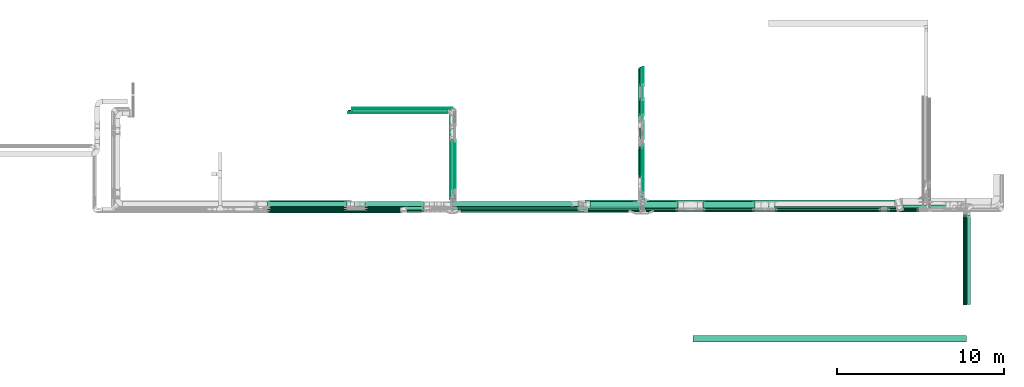
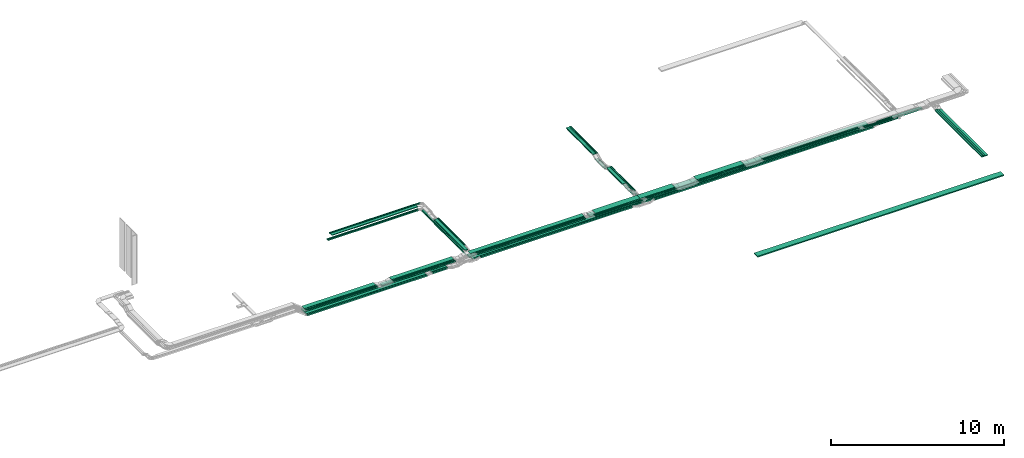
# One storey, part 2 of 28: 66 flow segments.
"""IFC2X3 building model written with IfcOpenShell, lengths in millimetres."""

from ifc_helpers import new_model, entity, si_unit, converted_unit, derived_unit, direction, frame, frame_2d, origin, origin_2d_with_axis, place, context, subcontext, project, spatial, rectangle, extrude, type_object, element, save


model = new_model("IFC2X3")

# Units and contexts
model_context = context("Model", 3, precision=0.01, world=origin(), true_north=direction((6.12303176911189e-17, 1.0)))
body_context = subcontext(model_context, "Body", "Model", "MODEL_VIEW")
ifc_project = project(units=[si_unit("LENGTHUNIT", "METRE", prefix="MILLI"), si_unit("AREAUNIT", "SQUARE_METRE"), si_unit("VOLUMEUNIT", "CUBIC_METRE"), converted_unit("PLANEANGLEUNIT", "DEGREE", entity("IfcRatioMeasure", 0.0174532925199433), si_unit("PLANEANGLEUNIT", "RADIAN"), dimensions=[0, 0, 0, 0, 0, 0, 0]), si_unit("MASSUNIT", "GRAM", prefix="KILO"), derived_unit("MASSDENSITYUNIT", [(si_unit("MASSUNIT", "GRAM", prefix="KILO"), 1), (si_unit("LENGTHUNIT", "METRE"), -3)]), derived_unit("MOMENTOFINERTIAUNIT", [(si_unit("LENGTHUNIT", "METRE"), 4)]), si_unit("TIMEUNIT", "SECOND"), si_unit("FREQUENCYUNIT", "HERTZ"), si_unit("THERMODYNAMICTEMPERATUREUNIT", "DEGREE_CELSIUS"), derived_unit("THERMALTRANSMITTANCEUNIT", [(si_unit("MASSUNIT", "GRAM", prefix="KILO"), 1), (si_unit("THERMODYNAMICTEMPERATUREUNIT", "KELVIN"), -1), (si_unit("TIMEUNIT", "SECOND"), -3)]), derived_unit("VOLUMETRICFLOWRATEUNIT", [(si_unit("LENGTHUNIT", "METRE"), 3), (si_unit("TIMEUNIT", "SECOND"), -1)]), derived_unit("MASSFLOWRATEUNIT", [(si_unit("MASSUNIT", "GRAM", prefix="KILO"), 1), (si_unit("TIMEUNIT", "SECOND"), -1)]), derived_unit("ROTATIONALFREQUENCYUNIT", [(si_unit("TIMEUNIT", "SECOND"), -1)]), si_unit("ELECTRICCURRENTUNIT", "AMPERE"), si_unit("ELECTRICVOLTAGEUNIT", "VOLT"), si_unit("POWERUNIT", "WATT"), si_unit("FORCEUNIT", "NEWTON", prefix="KILO"), si_unit("ILLUMINANCEUNIT", "LUX"), si_unit("LUMINOUSFLUXUNIT", "LUMEN"), si_unit("LUMINOUSINTENSITYUNIT", "CANDELA"), derived_unit("USERDEFINED", [(si_unit("MASSUNIT", "GRAM", prefix="KILO"), -1), (si_unit("LENGTHUNIT", "METRE"), -2), (si_unit("TIMEUNIT", "SECOND"), 3), (si_unit("LUMINOUSFLUXUNIT", "LUMEN"), 1)]), derived_unit("LINEARVELOCITYUNIT", [(si_unit("LENGTHUNIT", "METRE"), 1), (si_unit("TIMEUNIT", "SECOND"), -1)]), si_unit("PRESSUREUNIT", "PASCAL"), derived_unit("USERDEFINED", [(si_unit("LENGTHUNIT", "METRE"), -2), (si_unit("MASSUNIT", "GRAM", prefix="KILO"), 1), (si_unit("TIMEUNIT", "SECOND"), -2)]), derived_unit("LINEARFORCEUNIT", [(si_unit("MASSUNIT", "GRAM", prefix="KILO"), 1), (si_unit("LENGTHUNIT", "METRE"), 1), (si_unit("TIMEUNIT", "SECOND"), -2), (si_unit("LENGTHUNIT", "METRE"), -1)]), derived_unit("PLANARFORCEUNIT", [(si_unit("MASSUNIT", "GRAM", prefix="KILO"), 1), (si_unit("LENGTHUNIT", "METRE"), 1), (si_unit("TIMEUNIT", "SECOND"), -2), (si_unit("LENGTHUNIT", "METRE"), -2)])], contexts=[model_context])

# Site, building, storey
site_placement = place(None, frame((0.0, -0.00077364408347762, 0.0)))
site = spatial("IfcSite", under=ifc_project, at=site_placement, CompositionType="ELEMENT")
building_placement = place(site_placement, origin())
building = spatial("IfcBuilding", under=site, at=building_placement, CompositionType="ELEMENT")
storey_placement = place(building_placement, origin())
storey = spatial("IfcBuildingStorey", under=building, at=storey_placement, CompositionType="ELEMENT", Elevation=0.0)

# Flow segments
cable_carrier_segment_type = type_object("IfcCableCarrierSegmentType", PredefinedType="CABLETRAYSEGMENT")
flow_segment_1_placement = place(storey_placement, frame((54929.7964531974, 8300.00006103523, 2850.0)))
element("IfcFlowSegment", 1, at=flow_segment_1_placement, inside=storey, type_object=cable_carrier_segment_type, context=body_context, shape_type="SweptSolid", body=[
    extrude(rectangle(XDim=6370.08732356079, YDim=99.9999999999989, at=frame_2d((4.54747350886464e-12, 5.40012479177676e-13), x_axis=(1.0, 0.0))), frame((3185.04366178039, 50.0, 0.0), z_axis=(0.0, 0.0, 1.0), x_axis=(-1.0, 0.0, 0.0)), (0.0, 0.0, 1.0), 49.9999999999995),
])
flow_segment_2_placement = place(storey_placement, frame((47132.1688929495, 8410.00006103511, 2850.0)))
element("IfcFlowSegment", 2, at=flow_segment_2_placement, inside=storey, type_object=cable_carrier_segment_type, context=body_context, shape_type="SweptSolid", body=[
    extrude(rectangle(XDim=2006.37627300281, YDim=100.000000000001, at=frame_2d((0.0, -5.43565192856477e-13), x_axis=(1.0, 0.0))), frame((1003.18813650141, 50.0, 0.0)), (0.0, 0.0, 1.0), 49.9999999999995),
])
flow_segment_3_placement = place(storey_placement, frame((46843.1849606245, 8520.00006103514, 2850.0)))
element("IfcFlowSegment", 3, at=flow_segment_3_placement, inside=storey, type_object=cable_carrier_segment_type, context=body_context, shape_type="SweptSolid", body=[
    extrude(rectangle(XDim=2295.36020532801, YDim=400.0, at=frame_2d((4.32009983342141e-12, 0.0), x_axis=(1.0, 0.0))), frame((1147.68010266401, 200.0, 0.0)), (0.0, 0.0, 1.0), 49.9999999999995),
])
flow_segment_4_placement = place(storey_placement, frame((35521.1085349589, 8620.00006103516, 2600.0)))
element("IfcFlowSegment", 4, at=flow_segment_4_placement, inside=storey, type_object=cable_carrier_segment_type, context=body_context, shape_type="SweptSolid", body=[
    extrude(rectangle(XDim=7219.09376803744, YDim=299.999999999999, at=frame_2d((-2.04636307898909e-12, 5.40012479177676e-13), x_axis=(1.0, 0.0))), frame((3609.54688401872, 150.0, 0.0)), (0.0, 0.0, 1.0), 100.0),
])
flow_segment_5_placement = place(storey_placement, frame((24527.3148481445, 8570.00006103521, 2600.0)))
element("IfcFlowSegment", 5, at=flow_segment_5_placement, inside=storey, type_object=cable_carrier_segment_type, context=body_context, shape_type="SweptSolid", body=[
    extrude(rectangle(XDim=4983.74700171906, YDim=400.0, at=frame_2d((0.0, -5.54223333892878e-13), x_axis=(1.0, 0.0))), frame((2491.87350085953, 200.0, 0.0), z_axis=(0.0, 0.0, 1.0), x_axis=(-1.0, 0.0, 0.0)), (0.0, 0.0, 1.0), 100.0),
])
flow_segment_6_placement = place(storey_placement, frame((62655.5743759365, 8400.00006103516, 2600.0)))
element("IfcFlowSegment", 6, at=flow_segment_6_placement, inside=storey, type_object=cable_carrier_segment_type, context=body_context, shape_type="SweptSolid", body=[
    extrude(rectangle(XDim=1271.610584688, YDim=99.9999999999989, at=frame_2d((-4.32009983342141e-12, 1.08357767203415e-12), x_axis=(1.0, 0.0))), frame((635.805292344005, 50.0, 0.0)), (0.0, 0.0, 1.0), 100.0),
])
flow_segment_7_placement = place(storey_placement, frame((46898.1697248974, 8410.17178445353, 2600.0)))
element("IfcFlowSegment", 7, at=flow_segment_7_placement, inside=storey, type_object=cable_carrier_segment_type, context=body_context, shape_type="SweptSolid", body=[
    extrude(rectangle(XDim=15296.8333798477, YDim=200.0, at=origin_2d_with_axis()), frame((7648.41668992383, 100.0, 0.0), z_axis=(0.0, 0.0, 1.0), x_axis=(-1.0, 0.0, 0.0)), (0.0, 0.0, 1.0), 100.0),
])
flow_segment_8_placement = place(storey_placement, frame((47045.820904201, 8620.17178445353, 2600.0)))
element("IfcFlowSegment", 8, at=flow_segment_8_placement, inside=storey, type_object=cable_carrier_segment_type, context=body_context, shape_type="SweptSolid", body=[
    extrude(rectangle(XDim=15060.2769853209, YDim=400.0, at=frame_2d((-4.54747350886464e-12, 5.54223333892878e-13), x_axis=(1.0, 0.0))), frame((7530.13849266045, 200.0, 0.0), z_axis=(0.0, 0.0, 1.0), x_axis=(-1.0, 0.0, 0.0)), (0.0, 0.0, 1.0), 100.0),
])
flow_segment_9_placement = place(storey_placement, frame((62638.6221876818, 8514.3275570197, 2600.0)))
element("IfcFlowSegment", 9, at=flow_segment_9_placement, inside=storey, type_object=cable_carrier_segment_type, context=body_context, shape_type="SweptSolid", body=[
    extrude(rectangle(XDim=1418.74753721558, YDim=200.0, at=frame_2d((4.32009983342141e-12, 0.0), x_axis=(1.0, 0.0))), frame((709.373768607787, 100.0, 0.0)), (0.0, 0.0, 1.0), 100.0),
])
flow_segment_10_placement = place(storey_placement, frame((64058.1697248974, 8514.3275570197, 2600.0)))
element("IfcFlowSegment", 10, at=flow_segment_10_placement, inside=storey, type_object=cable_carrier_segment_type, context=body_context, shape_type="SweptSolid", body=[
    extrude(rectangle(XDim=1550.00000000001, YDim=200.0, at=frame_2d((0.0, 5.47117906535277e-13), x_axis=(1.0, 0.0))), frame((775.0, 100.0, 0.0)), (0.0, 0.0, 1.0), 100.000000000001),
])
flow_segment_11_placement = place(storey_placement, frame((46847.7697248975, 15822.7995563986, 2600.0)))
element("IfcFlowSegment", 11, at=flow_segment_11_placement, inside=storey, type_object=cable_carrier_segment_type, context=body_context, shape_type="SweptSolid", body=[
    extrude(rectangle(XDim=1137.0957799209, YDim=99.9999999999946, at=origin_2d_with_axis()), frame((50.0, 568.547889960451, 0.0), z_axis=(0.0, 0.0, 1.0), x_axis=(0.0, 1.0, 0.0)), (0.0, 0.0, 1.0), 49.9999999999995),
])
flow_segment_12_placement = place(storey_placement, frame((47012.1849606245, 13790.7712572773, 2800.0)))
element("IfcFlowSegment", 12, at=flow_segment_12_placement, inside=storey, type_object=cable_carrier_segment_type, context=body_context, shape_type="SweptSolid", body=[
    extrude(rectangle(XDim=3099.22880375789, YDim=50.000000000006, at=frame_2d((2.1600499167107e-12, -4.33253433129721e-12), x_axis=(1.0, 0.0))), frame((25.0, 1549.61440187894, 0.0), z_axis=(0.0, 0.0, 1.0), x_axis=(0.0, 1.0, 0.0)), (0.0, 0.0, 1.0), 49.9999999999995),
])
flow_segment_13_placement = place(storey_placement, frame((46952.1849606245, 13790.7712572773, 2800.0)))
element("IfcFlowSegment", 13, at=flow_segment_13_placement, inside=storey, type_object=cable_carrier_segment_type, context=body_context, shape_type="SweptSolid", body=[
    extrude(rectangle(XDim=3099.22880375789, YDim=50.000000000006, at=frame_2d((2.1600499167107e-12, 4.33253433129721e-12), x_axis=(1.0, 0.0))), frame((25.0, 1549.61440187894, 0.0), z_axis=(0.0, 0.0, 1.0), x_axis=(0.0, 1.0, 0.0)), (0.0, 0.0, 1.0), 49.9999999999995),
])
flow_segment_14_placement = place(storey_placement, frame((47019.8209042011, 15822.7995564001, 2600.0)))
element("IfcFlowSegment", 14, at=flow_segment_14_placement, inside=storey, type_object=cable_carrier_segment_type, context=body_context, shape_type="SweptSolid", body=[
    extrude(rectangle(XDim=1137.09577991943, YDim=50.000000000006, at=frame_2d((2.1600499167107e-12, 4.33253433129721e-12), x_axis=(1.0, 0.0))), frame((25.0, 568.547889959712, 0.0), z_axis=(0.0, 0.0, 1.0), x_axis=(0.0, 1.0, 0.0)), (0.0, 0.0, 1.0), 50.0000000000005),
])
flow_segment_15_placement = place(storey_placement, frame((32876.6496180189, 8410.17178445353, 2600.0)))
element("IfcFlowSegment", 15, at=flow_segment_15_placement, inside=storey, type_object=cable_carrier_segment_type, context=body_context, shape_type="SweptSolid", body=[
    extrude(rectangle(XDim=1039.99874618809, YDim=200.0, at=frame_2d((0.0, -5.47117906535277e-13), x_axis=(1.0, 0.0))), frame((519.999373094047, 100.0, 0.0)), (0.0, 0.0, 1.0), 100.000000000001),
])
flow_segment_16_placement = place(storey_placement, frame((43583.820904201, 8620.17178445353, 2600.0)))
element("IfcFlowSegment", 16, at=flow_segment_16_placement, inside=storey, type_object=cable_carrier_segment_type, context=body_context, shape_type="SweptSolid", body=[
    extrude(rectangle(XDim=3460.0, YDim=400.0, at=frame_2d((4.32009983342141e-12, 0.0), x_axis=(1.0, 0.0))), frame((1730.0, 200.0, 0.0), z_axis=(0.0, 0.0, 1.0), x_axis=(-1.0, 0.0, 0.0)), (0.0, 0.0, 1.0), 100.0),
])
flow_segment_17_placement = place(storey_placement, frame((47688.7915300672, 8300.17178445353, 2600.0)))
element("IfcFlowSegment", 17, at=flow_segment_17_placement, inside=storey, type_object=cable_carrier_segment_type, context=body_context, shape_type="SweptSolid", body=[
    extrude(rectangle(XDim=14552.3620361267, YDim=100.000000000001, at=frame_2d((4.54747350886464e-12, 5.43565192856477e-13), x_axis=(1.0, 0.0))), frame((7276.18101806337, 50.0, 0.0)), (0.0, 0.0, 1.0), 100.0),
])
flow_segment_18_placement = place(storey_placement, frame((46742.1849606245, 13790.7712572773, 2800.0)))
element("IfcFlowSegment", 18, at=flow_segment_18_placement, inside=storey, type_object=cable_carrier_segment_type, context=body_context, shape_type="SweptSolid", body=[
    extrude(rectangle(XDim=3099.2288037579, YDim=200.000000000007, at=frame_2d((-2.1600499167107e-12, 0.0), x_axis=(1.0, 0.0))), frame((100.0, 1549.61440187895, 0.0), z_axis=(0.0, 0.0, 1.0), x_axis=(0.0, 1.0, 0.0)), (0.0, 0.0, 1.0), 50.0000000000005),
])
flow_segment_19_placement = place(storey_placement, frame((43861.1849606245, 8520.00006103515, 2850.0)))
element("IfcFlowSegment", 19, at=flow_segment_19_placement, inside=storey, type_object=cable_carrier_segment_type, context=body_context, shape_type="SweptSolid", body=[
    extrude(rectangle(XDim=2980.00000000002, YDim=400.0, at=origin_2d_with_axis()), frame((1490.0, 200.0, 0.0), z_axis=(0.0, 0.0, 1.0), x_axis=(-1.0, 0.0, 0.0)), (0.0, 0.0, 1.0), 49.9999999999995),
])
flow_segment_20_placement = place(storey_placement, frame((35555.108534959, 9465.53072035415, 2600.0)))
element("IfcFlowSegment", 20, at=flow_segment_20_placement, inside=storey, type_object=cable_carrier_segment_type, context=body_context, shape_type="SweptSolid", body=[
    extrude(rectangle(XDim=4668.46927962027, YDim=100.000000000003, at=frame_2d((-1.13686837721616e-12, 4.33431068813661e-12), x_axis=(1.0, 0.0))), frame((50.0, 2334.23463981013, 0.0), z_axis=(0.0, 0.0, 1.0), x_axis=(0.0, 1.0, 0.0)), (0.0, 0.0, 1.0), 49.9999999999995),
])
flow_segment_21_placement = place(storey_placement, frame((35767.4596505076, 9536.72340198595, 2850.0)))
element("IfcFlowSegment", 21, at=flow_segment_21_placement, inside=storey, type_object=cable_carrier_segment_type, context=body_context, shape_type="SweptSolid", body=[
    extrude(rectangle(XDim=3095.56319386164, YDim=49.9999999999973, at=frame_2d((5.6843418860808e-13, 0.0), x_axis=(1.0, 0.0))), frame((25.0, 1547.78159693082, 0.0), z_axis=(0.0, 0.0, 1.0), x_axis=(0.0, 1.0, 0.0)), (0.0, 0.0, 1.0), 50.0000000000005),
])
flow_segment_22_placement = place(storey_placement, frame((35707.4596505076, 9536.72340198596, 2850.0)))
element("IfcFlowSegment", 22, at=flow_segment_22_placement, inside=storey, type_object=cable_carrier_segment_type, context=body_context, shape_type="SweptSolid", body=[
    extrude(rectangle(XDim=3095.5631938618, YDim=49.9999999999973, at=frame_2d((-5.6843418860808e-13, 0.0), x_axis=(1.0, 0.0))), frame((25.0, 1547.7815969309, 0.0), z_axis=(0.0, 0.0, 1.0), x_axis=(0.0, -1.0, 0.0)), (0.0, 0.0, 1.0), 50.0000000000005),
])
flow_segment_23_placement = place(storey_placement, frame((35495.108534959, 9070.00006103513, 2850.0)))
element("IfcFlowSegment", 23, at=flow_segment_23_placement, inside=storey, type_object=cable_carrier_segment_type, context=body_context, shape_type="SweptSolid", body=[
    extrude(rectangle(XDim=3562.28653481264, YDim=199.999999999998, at=frame_2d((4.54747350886464e-13, 0.0), x_axis=(1.0, 0.0))), frame((100.0, 1781.14326740632, 0.0), z_axis=(0.0, 0.0, 1.0), x_axis=(0.0, 1.0, 0.0)), (0.0, 0.0, 1.0), 50.0000000000005),
])
flow_segment_24_placement = place(storey_placement, frame((29362.4596505076, 14285.0, 2600.0)))
element("IfcFlowSegment", 24, at=flow_segment_24_placement, inside=storey, type_object=cable_carrier_segment_type, context=body_context, shape_type="SweptSolid", body=[
    extrude(rectangle(XDim=6041.64888445136, YDim=99.9999999999989, at=frame_2d((-4.32009983342141e-12, 0.0), x_axis=(1.0, 0.0))), frame((3020.82444222568, 50.0, 0.0), z_axis=(0.0, 0.0, 1.0), x_axis=(-1.0, 0.0, 0.0)), (0.0, 0.0, 1.0), 49.9999999999995),
])
flow_segment_25_placement = place(storey_placement, frame((35495.1085349589, 9060.00006103524, 2600.0)))
element("IfcFlowSegment", 25, at=flow_segment_25_placement, inside=storey, type_object=cable_carrier_segment_type, context=body_context, shape_type="SweptSolid", body=[
    extrude(rectangle(XDim=5013.99993893918, YDim=49.9999999999973, at=frame_2d((-4.54747350886464e-13, 2.16537898722891e-12), x_axis=(1.0, 0.0))), frame((25.0, 2506.99996946959, 0.0), z_axis=(0.0, 0.0, 1.0), x_axis=(0.0, 1.0, 0.0)), (0.0, 0.0, 1.0), 50.0000000000005),
])
flow_segment_26_placement = place(storey_placement, frame((29362.4596505076, 14225.0, 2600.0)))
element("IfcFlowSegment", 26, at=flow_segment_26_placement, inside=storey, type_object=cable_carrier_segment_type, context=body_context, shape_type="SweptSolid", body=[
    extrude(rectangle(XDim=5981.64888445141, YDim=50.0000000000016, at=frame_2d((-2.27373675443232e-12, 0.0), x_axis=(1.0, 0.0))), frame((2990.82444222571, 25.0, 0.0), z_axis=(0.0, 0.0, 1.0), x_axis=(-1.0, 0.0, 0.0)), (0.0, 0.0, 1.0), 49.9999999999995),
])
flow_segment_27_placement = place(storey_placement, frame((29612.4596505076, 14495.0, 2850.0)))
element("IfcFlowSegment", 27, at=flow_segment_27_placement, inside=storey, type_object=cable_carrier_segment_type, context=body_context, shape_type="SweptSolid", body=[
    extrude(rectangle(XDim=6025.00000000003, YDim=50.0000000000016, at=frame_2d((0.0, 1.08357767203415e-12), x_axis=(1.0, 0.0))), frame((3012.50000000001, 25.0, 0.0), z_axis=(0.0, 0.0, 1.0), x_axis=(-1.0, 0.0, 0.0)), (0.0, 0.0, 1.0), 50.0000000000005),
])
flow_segment_28_placement = place(storey_placement, frame((29612.4596505076, 14435.0, 2850.0)))
element("IfcFlowSegment", 28, at=flow_segment_28_placement, inside=storey, type_object=cable_carrier_segment_type, context=body_context, shape_type="SweptSolid", body=[
    extrude(rectangle(XDim=5944.00000000003, YDim=50.0000000000016, at=frame_2d((-2.04636307898909e-12, -1.08357767203415e-12), x_axis=(1.0, 0.0))), frame((2972.0, 25.0, 0.0), z_axis=(0.0, 0.0, 1.0), x_axis=(-1.0, 0.0, 0.0)), (0.0, 0.0, 1.0), 50.0000000000005),
])
flow_segment_29_placement = place(storey_placement, frame((29612.4596505076, 14225.0, 2850.0)))
element("IfcFlowSegment", 29, at=flow_segment_29_placement, inside=storey, type_object=cable_carrier_segment_type, context=body_context, shape_type="SweptSolid", body=[
    extrude(rectangle(XDim=5731.6488844514, YDim=200.000000000002, at=frame_2d((4.32009983342141e-12, 0.0), x_axis=(1.0, 0.0))), frame((2865.8244422257, 100.0, 0.0), z_axis=(0.0, 0.0, 1.0), x_axis=(-1.0, 0.0, 0.0)), (0.0, 0.0, 1.0), 49.9999999999995),
])
flow_segment_30_placement = place(storey_placement, frame((30367.0121689451, 8620.00006103513, 2850.0)))
element("IfcFlowSegment", 30, at=flow_segment_30_placement, inside=storey, type_object=cable_carrier_segment_type, context=body_context, shape_type="SweptSolid", body=[
    extrude(rectangle(XDim=4130.35917387728, YDim=300.000000000001, at=frame_2d((2.04636307898909e-12, -1.08002495835535e-12), x_axis=(1.0, 0.0))), frame((2065.17958693863, 150.0, 0.0)), (0.0, 0.0, 1.0), 49.9999999999995),
])
flow_segment_31_placement = place(storey_placement, frame((30367.012168945, 8510.00006103506, 2850.0)))
element("IfcFlowSegment", 31, at=flow_segment_31_placement, inside=storey, type_object=cable_carrier_segment_type, context=body_context, shape_type="SweptSolid", body=[
    extrude(rectangle(XDim=4130.35917387756, YDim=100.000000000001, at=frame_2d((0.0, -1.08357767203415e-12), x_axis=(1.0, 0.0))), frame((2065.17958693878, 50.0, 0.0), z_axis=(0.0, 0.0, 1.0), x_axis=(-1.0, 0.0, 0.0)), (0.0, 0.0, 1.0), 50.0000000000011),
])
flow_segment_32_placement = place(storey_placement, frame((30367.0121689451, 8400.00006103518, 2850.0)))
element("IfcFlowSegment", 32, at=flow_segment_32_placement, inside=storey, type_object=cable_carrier_segment_type, context=body_context, shape_type="SweptSolid", body=[
    extrude(rectangle(XDim=4130.35917387749, YDim=100.000000000001, at=frame_2d((2.27373675443232e-12, 0.0), x_axis=(1.0, 0.0))), frame((2065.17958693874, 50.0, 0.0), z_axis=(0.0, 0.0, 1.0), x_axis=(-1.0, 0.0, 0.0)), (0.0, 0.0, 1.0), 49.9999999999995),
])
flow_segment_33_placement = place(storey_placement, frame((50627.8063116425, 8410.00006103511, 2849.99977902447)))
element("IfcFlowSegment", 33, at=flow_segment_33_placement, inside=storey, type_object=cable_carrier_segment_type, context=body_context, shape_type="SweptSolid", body=[
    extrude(rectangle(XDim=3111.50022738776, YDim=99.9999999999989, at=frame_2d((4.32009983342141e-12, -5.40012479177676e-13), x_axis=(1.0, 0.0))), frame((1555.75011369388, 50.0, 0.000110293772502246), z_axis=(7.08942723260704e-08, 0.0, 1.0), x_axis=(-1.0, 0.0, 7.08942723260704e-08)), (0.0, 0.0, 1.0), 49.9999999999996),
])
flow_segment_34_placement = place(storey_placement, frame((47199.820904201, 8300.00006103523, 2850.0)))
element("IfcFlowSegment", 34, at=flow_segment_34_placement, inside=storey, type_object=cable_carrier_segment_type, context=body_context, shape_type="SweptSolid", body=[
    extrude(rectangle(XDim=1938.72426175145, YDim=99.9999999999989, at=frame_2d((0.0, 1.08357767203415e-12), x_axis=(1.0, 0.0))), frame((969.362130875724, 50.0, 0.0)), (0.0, 0.0, 1.0), 49.9999999999995),
])
flow_segment_35_placement = place(storey_placement, frame((47019.820904201, 9060.0000610352, 2600.0)))
element("IfcFlowSegment", 35, at=flow_segment_35_placement, inside=storey, type_object=cable_carrier_segment_type, context=body_context, shape_type="SweptSolid", body=[
    extrude(rectangle(XDim=3286.61163187284, YDim=50.000000000006, at=frame_2d((1.02318153949454e-12, 0.0), x_axis=(1.0, 0.0))), frame((25.0, 1643.30581593642, 0.0), z_axis=(0.0, 0.0, 1.0), x_axis=(0.0, -1.0, 0.0)), (0.0, 0.0, 1.0), 49.9999999999995),
])
flow_segment_36_placement = place(storey_placement, frame((46847.7697248974, 9444.27066099226, 2600.0)))
element("IfcFlowSegment", 36, at=flow_segment_36_placement, inside=storey, type_object=cable_carrier_segment_type, context=body_context, shape_type="SweptSolid", body=[
    extrude(rectangle(XDim=2902.34103191558, YDim=99.9999999999946, at=frame_2d((-1.13686837721616e-12, 0.0), x_axis=(1.0, 0.0))), frame((50.0, 1451.17051595779, 0.0), z_axis=(0.0, 0.0, 1.0), x_axis=(0.0, 1.0, 0.0)), (0.0, 0.0, 1.0), 49.9999999999995),
])
flow_segment_37_placement = place(storey_placement, frame((47019.8209042011, 12660.0000610357, 2450.0)))
element("IfcFlowSegment", 37, at=flow_segment_37_placement, inside=storey, type_object=cable_carrier_segment_type, context=body_context, shape_type="SweptSolid", body=[
    extrude(rectangle(XDim=1103.60147622474, YDim=50.000000000006, at=frame_2d((1.08002495835535e-12, 0.0), x_axis=(1.0, 0.0))), frame((25.0, 551.80073811237, 0.0), z_axis=(0.0, 0.0, 1.0), x_axis=(0.0, -1.0, 0.0)), (0.0, 0.0, 1.0), 50.0000000000005),
])
flow_segment_38_placement = place(storey_placement, frame((46847.7697248975, 12660.0000610352, 2450.0)))
element("IfcFlowSegment", 38, at=flow_segment_38_placement, inside=storey, type_object=cable_carrier_segment_type, context=body_context, shape_type="SweptSolid", body=[
    extrude(rectangle(XDim=1103.60147622524, YDim=99.9999999999946, at=frame_2d((1.08002495835535e-12, 0.0), x_axis=(1.0, 0.0))), frame((50.0, 551.800738112621, 0.0), z_axis=(0.0, 0.0, 1.0), x_axis=(0.0, -1.0, 0.0)), (0.0, 0.0, 1.0), 50.0000000000005),
])
flow_segment_39_placement = place(storey_placement, frame((47020.122130859, 9428.95026141598, 2800.0)))
element("IfcFlowSegment", 39, at=flow_segment_39_placement, inside=storey, type_object=cable_carrier_segment_type, context=body_context, shape_type="SweptSolid", body=[
    extrude(rectangle(XDim=2803.04946350503, YDim=50.000000000006, at=frame_2d((1.02318153949454e-12, 0.0), x_axis=(1.0, 0.0))), frame((25.0, 1401.52473175252, 0.0), z_axis=(0.0, 0.0, 1.0), x_axis=(0.0, 1.0, 0.0)), (0.0, 0.0, 1.0), 49.9999999999995),
])
flow_segment_40_placement = place(storey_placement, frame((46959.820904201, 9428.95026141597, 2800.0)))
element("IfcFlowSegment", 40, at=flow_segment_40_placement, inside=storey, type_object=cable_carrier_segment_type, context=body_context, shape_type="SweptSolid", body=[
    extrude(rectangle(XDim=2795.15412443013, YDim=50.000000000006, at=frame_2d((5.6843418860808e-13, 0.0), x_axis=(1.0, 0.0))), frame((25.0, 1397.57706221506, 0.0), z_axis=(0.0, 0.0, 1.0), x_axis=(0.0, 1.0, 0.0)), (0.0, 0.0, 1.0), 50.0000000000005),
])
flow_segment_41_placement = place(storey_placement, frame((46742.1849606245, 10356.9539520636, 2800.0)))
element("IfcFlowSegment", 41, at=flow_segment_41_placement, inside=storey, type_object=cable_carrier_segment_type, context=body_context, shape_type="SweptSolid", body=[
    extrude(rectangle(XDim=1867.15043378258, YDim=200.000000000007, at=origin_2d_with_axis()), frame((100.0, 933.575216891291, 0.0), z_axis=(0.0, 0.0, 1.0), x_axis=(0.0, -1.0, 0.0)), (0.0, 0.0, 1.0), 50.0000000000005),
])
flow_segment_42_placement = place(storey_placement, frame((35947.5955940841, 8400.00006103518, 2850.0)))
element("IfcFlowSegment", 42, at=flow_segment_42_placement, inside=storey, type_object=cable_carrier_segment_type, context=body_context, shape_type="SweptSolid", body=[
    extrude(rectangle(XDim=7185.91505426564, YDim=99.9999999999989, at=frame_2d((-2.27373675443232e-12, -5.40012479177676e-13), x_axis=(1.0, 0.0))), frame((3592.95752713282, 50.0, 0.0), z_axis=(0.0, 0.0, 1.0), x_axis=(-1.0, 0.0, 0.0)), (0.0, 0.0, 1.0), 49.9999999999995),
])
flow_segment_43_placement = place(storey_placement, frame((36110.1031412704, 8290.00006103516, 2600.0)))
element("IfcFlowSegment", 43, at=flow_segment_43_placement, inside=storey, type_object=cable_carrier_segment_type, context=body_context, shape_type="SweptSolid", body=[
    extrude(rectangle(XDim=10071.3033738979, YDim=99.9999999999989, at=origin_2d_with_axis()), frame((5035.65168694897, 50.0, 0.0), z_axis=(0.0, 0.0, 1.0), x_axis=(-1.0, 0.0, 0.0)), (0.0, 0.0, 1.0), 100.0),
])
flow_segment_44_placement = place(storey_placement, frame((35887.4435828326, 8510.00006103506, 2850.0)))
element("IfcFlowSegment", 44, at=flow_segment_44_placement, inside=storey, type_object=cable_carrier_segment_type, context=body_context, shape_type="SweptSolid", body=[
    extrude(rectangle(XDim=7246.06706551713, YDim=99.9999999999989, at=frame_2d((2.27373675443232e-12, 5.40012479177676e-13), x_axis=(1.0, 0.0))), frame((3623.03353275856, 50.0, 0.0), z_axis=(0.0, 0.0, 1.0), x_axis=(-1.0, 0.0, 0.0)), (0.0, 0.0, 1.0), 49.9999999999995),
])
flow_segment_45_placement = place(storey_placement, frame((24527.3148481444, 8250.00006103526, 2600.0)))
element("IfcFlowSegment", 45, at=flow_segment_45_placement, inside=storey, type_object=cable_carrier_segment_type, context=body_context, shape_type="SweptSolid", body=[
    extrude(rectangle(XDim=7986.3573272726, YDim=99.9999999999989, at=frame_2d((0.0, -5.40012479177676e-13), x_axis=(1.0, 0.0))), frame((3993.1786636363, 50.0, 0.0), z_axis=(0.0, 0.0, 1.0), x_axis=(-1.0, 0.0, 0.0)), (0.0, 0.0, 1.0), 100.0),
])
flow_segment_46_placement = place(storey_placement, frame((29741.0618498636, 8620.00006103522, 2600.0)))
element("IfcFlowSegment", 46, at=flow_segment_46_placement, inside=storey, type_object=cable_carrier_segment_type, context=body_context, shape_type="SweptSolid", body=[
    extrude(rectangle(XDim=4175.58651434346, YDim=300.000000000001, at=frame_2d((-2.27373675443232e-12, -5.40012479177676e-13), x_axis=(1.0, 0.0))), frame((2087.79325717174, 150.0, 0.0)), (0.0, 0.0, 1.0), 100.0),
])
flow_segment_47_placement = place(storey_placement, frame((24545.2225989038, 8400.00006103519, 2850.0)))
element("IfcFlowSegment", 47, at=flow_segment_47_placement, inside=storey, type_object=cable_carrier_segment_type, context=body_context, shape_type="SweptSolid", body=[
    extrude(rectangle(XDim=4741.45457153696, YDim=100.000000000001, at=frame_2d((-4.32009983342141e-12, 5.43565192856477e-13), x_axis=(1.0, 0.0))), frame((2370.72728576849, 50.0, 0.0)), (0.0, 0.0, 1.0), 49.9999999999995),
])
flow_segment_48_placement = place(storey_placement, frame((24545.222598904, 8510.00006103506, 2850.0)))
element("IfcFlowSegment", 48, at=flow_segment_48_placement, inside=storey, type_object=cable_carrier_segment_type, context=body_context, shape_type="SweptSolid", body=[
    extrude(rectangle(XDim=4741.45457153696, YDim=100.000000000001, at=frame_2d((0.0, -5.43565192856477e-13), x_axis=(1.0, 0.0))), frame((2370.72728576848, 50.0, 0.0)), (0.0, 0.0, 1.0), 50.0000000000005),
])
flow_segment_49_placement = place(storey_placement, frame((24545.2225989041, 8620.00006103513, 2850.0)))
element("IfcFlowSegment", 49, at=flow_segment_49_placement, inside=storey, type_object=cable_carrier_segment_type, context=body_context, shape_type="SweptSolid", body=[
    extrude(rectangle(XDim=4741.45457153684, YDim=299.999999999999, at=frame_2d((2.27373675443232e-12, 5.40012479177676e-13), x_axis=(1.0, 0.0))), frame((2370.72728576843, 150.0, 0.0), z_axis=(0.0, 0.0, 1.0), x_axis=(-1.0, 0.0, 0.0)), (0.0, 0.0, 1.0), 50.0000000000005),
])
flow_segment_50_placement = place(storey_placement, frame((61658.7765895552, 8410.00006103523, 2750.0)))
element("IfcFlowSegment", 50, at=flow_segment_50_placement, inside=storey, type_object=cable_carrier_segment_type, context=body_context, shape_type="SweptSolid", body=[
    extrude(rectangle(XDim=1911.50856462211, YDim=100.000000000001, at=frame_2d((0.0, -5.43565192856477e-13), x_axis=(1.0, 0.0))), frame((955.754282311057, 50.0, 0.0)), (0.0, 0.0, 1.0), 49.9999999999995),
])
flow_segment_51_placement = place(storey_placement, frame((61658.7765895553, 8300.00006103519, 2750.0)))
element("IfcFlowSegment", 51, at=flow_segment_51_placement, inside=storey, type_object=cable_carrier_segment_type, context=body_context, shape_type="SweptSolid", body=[
    extrude(rectangle(XDim=1911.50856462196, YDim=99.9999999999989, at=frame_2d((0.0, 5.40012479177676e-13), x_axis=(1.0, 0.0))), frame((955.754282310979, 50.0, 0.0)), (0.0, 0.0, 1.0), 50.0000000000005),
])
flow_segment_52_placement = place(storey_placement, frame((54929.7964531974, 8410.00006103511, 2850.0)))
element("IfcFlowSegment", 52, at=flow_segment_52_placement, inside=storey, type_object=cable_carrier_segment_type, context=body_context, shape_type="SweptSolid", body=[
    extrude(rectangle(XDim=6370.08732356081, YDim=100.000000000001, at=frame_2d((0.0, 5.43565192856477e-13), x_axis=(1.0, 0.0))), frame((3185.04366178041, 50.0, 0.0), z_axis=(0.0, 0.0, 1.0), x_axis=(-1.0, 0.0, 0.0)), (0.0, 0.0, 1.0), 49.9999999999995),
])
flow_segment_53_placement = place(storey_placement, frame((50627.8063123624, 8300.00006103523, 2850.0)))
element("IfcFlowSegment", 53, at=flow_segment_53_placement, inside=storey, type_object=cable_carrier_segment_type, context=body_context, shape_type="SweptSolid", body=[
    extrude(rectangle(XDim=3111.4986535571, YDim=100.000000000001, at=frame_2d((0.0, 1.08357767203415e-12), x_axis=(1.0, 0.0))), frame((1555.74932677855, 50.0, 0.0), z_axis=(0.0, 0.0, 1.0), x_axis=(-1.0, 0.0, 0.0)), (0.0, 0.0, 1.0), 49.9999999999995),
])
flow_segment_54_placement = place(storey_placement, frame((50627.8063123624, 8520.00006103515, 2850.0)))
element("IfcFlowSegment", 54, at=flow_segment_54_placement, inside=storey, type_object=cable_carrier_segment_type, context=body_context, shape_type="SweptSolid", body=[
    extrude(rectangle(XDim=3111.49865355683, YDim=400.0, at=frame_2d((-4.32009983342141e-12, 5.54223333892878e-13), x_axis=(1.0, 0.0))), frame((1555.74932677841, 200.0, 0.0), z_axis=(0.0, 0.0, 1.0), x_axis=(-1.0, 0.0, 0.0)), (0.0, 0.0, 1.0), 50.0000000000005),
])
flow_segment_55_placement = place(storey_placement, frame((47019.8209042011, 14076.9899053831, 2600.0)))
element("IfcFlowSegment", 55, at=flow_segment_55_placement, inside=storey, type_object=cable_carrier_segment_type, context=body_context, shape_type="SweptSolid", body=[
    extrude(rectangle(XDim=1028.29671107794, YDim=50.000000000006, at=origin_2d_with_axis()), frame((25.0, 514.148355538971, 0.0), z_axis=(0.0, 0.0, 1.0), x_axis=(0.0, 1.0, 0.0)), (0.0, 0.0, 1.0), 49.9999999999995),
])
flow_segment_56_placement = place(storey_placement, frame((46847.7697248975, 14076.9899053875, 2600.0)))
element("IfcFlowSegment", 56, at=flow_segment_56_placement, inside=storey, type_object=cable_carrier_segment_type, context=body_context, shape_type="SweptSolid", body=[
    extrude(rectangle(XDim=1028.29671107504, YDim=99.9999999999946, at=frame_2d((0.0, 4.33075797445781e-12), x_axis=(1.0, 0.0))), frame((50.0, 514.148355537522, 0.0), z_axis=(0.0, 0.0, 1.0), x_axis=(0.0, 1.0, 0.0)), (0.0, 0.0, 1.0), 49.9999999999995),
])
flow_segment_57_placement = place(storey_placement, frame((35596.108534959, 8620.00006103513, 2850.0)))
element("IfcFlowSegment", 57, at=flow_segment_57_placement, inside=storey, type_object=cable_carrier_segment_type, context=body_context, shape_type="SweptSolid", body=[
    extrude(rectangle(XDim=7580.94324085374, YDim=300.000000000001, at=frame_2d((-2.04636307898909e-12, 0.0), x_axis=(1.0, 0.0))), frame((3790.47162042687, 150.0, 0.0)), (0.0, 0.0, 1.0), 50.0000000000005),
])
flow_segment_58_placement = place(storey_placement, frame((43737.0096881185, 8410.00006103511, 2850.0)))
element("IfcFlowSegment", 58, at=flow_segment_58_placement, inside=storey, type_object=cable_carrier_segment_type, context=body_context, shape_type="SweptSolid", body=[
    extrude(rectangle(XDim=3085.15920483105, YDim=99.9999999999989, at=frame_2d((-4.32009983342141e-12, 5.40012479177676e-13), x_axis=(1.0, 0.0))), frame((1542.57960241553, 50.0, 0.0)), (0.0, 0.0, 1.0), 49.9999999999995),
])
flow_segment_59_placement = place(storey_placement, frame((43737.0096881185, 8300.00006103523, 2850.0)))
element("IfcFlowSegment", 59, at=flow_segment_59_placement, inside=storey, type_object=cable_carrier_segment_type, context=body_context, shape_type="SweptSolid", body=[
    extrude(rectangle(XDim=3152.81121608253, YDim=99.9999999999989, at=frame_2d((4.32009983342141e-12, 0.0), x_axis=(1.0, 0.0))), frame((1576.40560804126, 50.0, 0.0)), (0.0, 0.0, 1.0), 49.9999999999995),
])
flow_segment_60_placement = place(storey_placement, frame((35605.508534959, 8410.17178445353, 2600.0)))
element("IfcFlowSegment", 60, at=flow_segment_60_placement, inside=storey, type_object=cable_carrier_segment_type, context=body_context, shape_type="SweptSolid", body=[
    extrude(rectangle(XDim=11291.8611899384, YDim=200.0, at=frame_2d((-2.27373675443232e-12, 0.0), x_axis=(1.0, 0.0))), frame((5645.93059496922, 100.0, 0.0), z_axis=(0.0, 0.0, 1.0), x_axis=(-1.0, 0.0, 0.0)), (0.0, 0.0, 1.0), 100.0),
])
flow_segment_61_placement = place(storey_placement, frame((32890.2482262156, 8290.00006103515, 2600.0)))
element("IfcFlowSegment", 61, at=flow_segment_61_placement, inside=storey, type_object=cable_carrier_segment_type, context=body_context, shape_type="SweptSolid", body=[
    extrude(rectangle(XDim=1026.40013799145, YDim=100.000000000001, at=frame_2d((-2.21689333557151e-12, -5.43565192856477e-13), x_axis=(1.0, 0.0))), frame((513.200068995724, 50.0, 0.0), z_axis=(0.0, 0.0, 1.0), x_axis=(-1.0, 0.0, 0.0)), (0.0, 0.0, 1.0), 100.0),
])
flow_segment_62_placement = place(storey_placement, frame((24527.3148481444, 8360.00006103509, 2600.0)))
element("IfcFlowSegment", 62, at=flow_segment_62_placement, inside=storey, type_object=cable_carrier_segment_type, context=body_context, shape_type="SweptSolid", body=[
    extrude(rectangle(XDim=7959.95593546928, YDim=200.0, at=origin_2d_with_axis()), frame((3979.97796773464, 100.0, 0.0), z_axis=(0.0, 0.0, 1.0), x_axis=(-1.0, 0.0, 0.0)), (0.0, 0.0, 1.0), 100.0),
])
flow_segment_63_placement = place(storey_placement, frame((66224.9973266601, 2744.13454606688, 2500.0)))
element("IfcFlowSegment", 63, at=flow_segment_63_placement, inside=storey, type_object=cable_carrier_segment_type, context=body_context, shape_type="SweptSolid", body=[
    extrude(rectangle(XDim=5385.36941381057, YDim=99.9999999999946, at=origin_2d_with_axis()), frame((50.0, 2692.68470690529, 0.0), z_axis=(0.0, 0.0, 1.0), x_axis=(0.0, -1.0, 0.0)), (0.0, 0.0, 1.0), 100.0),
])
flow_segment_64_placement = place(storey_placement, frame((66334.9973266601, 2744.13454606689, 2500.0)))
element("IfcFlowSegment", 64, at=flow_segment_64_placement, inside=storey, type_object=cable_carrier_segment_type, context=body_context, shape_type="SweptSolid", body=[
    extrude(rectangle(XDim=5385.36941381055, YDim=99.9999999999946, at=frame_2d((1.13686837721616e-12, 0.0), x_axis=(1.0, 0.0))), frame((50.0, 2692.68470690528, 0.0), z_axis=(0.0, 0.0, 1.0), x_axis=(0.0, -1.0, 0.0)), (0.0, 0.0, 1.0), 100.0),
])
flow_segment_65_placement = place(storey_placement, frame((66444.9973266601, 2744.13454606688, 2500.0)))
element("IfcFlowSegment", 65, at=flow_segment_65_placement, inside=storey, type_object=cable_carrier_segment_type, context=body_context, shape_type="SweptSolid", body=[
    extrude(rectangle(XDim=5370.73706607355, YDim=200.000000000007, at=frame_2d((-4.54747350886464e-13, -8.66862137627322e-12), x_axis=(1.0, 0.0))), frame((100.0, 2685.36853303677, 0.0), z_axis=(0.0, 0.0, 1.0), x_axis=(0.0, -1.0, 0.0)), (0.0, 0.0, 1.0), 50.0000000000005),
])
flow_segment_66_placement = place(storey_placement, frame((50020.0002685546, 500.000671945332, 2500.0)))
element("IfcFlowSegment", 66, at=flow_segment_66_placement, inside=storey, type_object=cable_carrier_segment_type, context=body_context, shape_type="SweptSolid", body=[
    extrude(rectangle(XDim=16400.0, YDim=400.0, at=frame_2d((-4.54747350886464e-12, 0.0), x_axis=(1.0, 0.0))), frame((8200.0, 200.0, 0.0), z_axis=(0.0, 0.0, 1.0), x_axis=(-1.0, 0.0, 0.0)), (0.0, 0.0, 1.0), 80.0000000000002),
])

save(model, "model.ifc")
